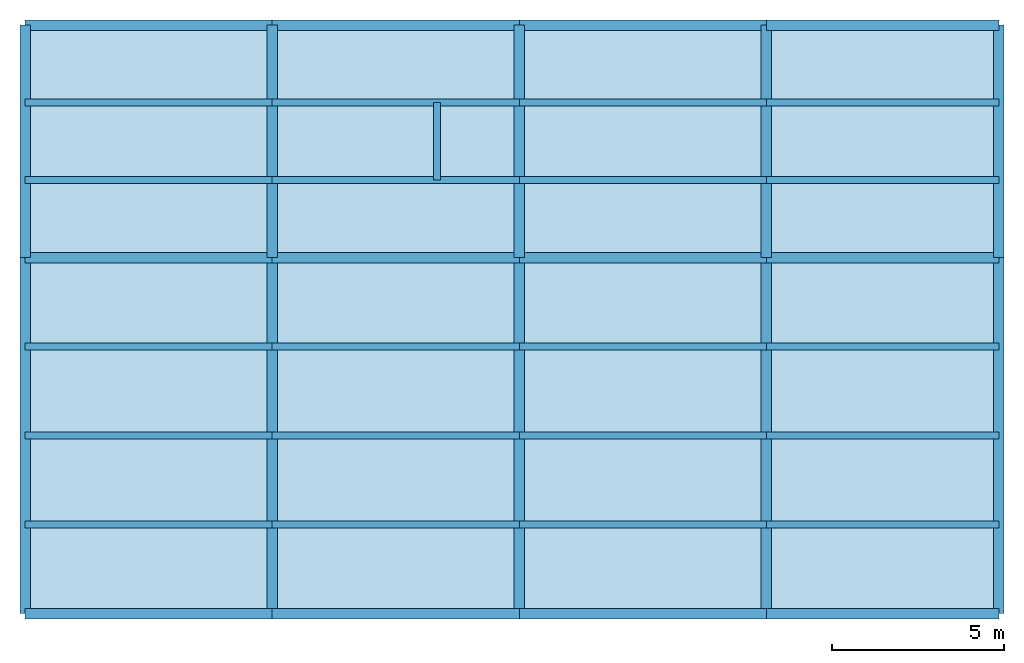
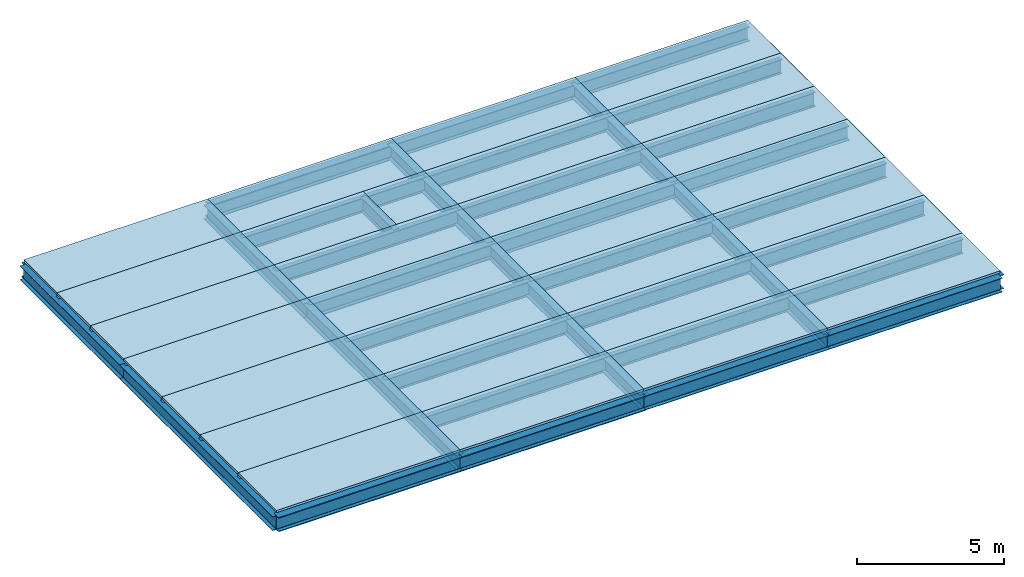
# One storey: 43 beams, 29 slabs.
"""IFC2X3 building model written with IfcOpenShell, lengths in millimetres."""

from ifc_helpers import new_model, si_unit, frame, origin_with_axes, origin_2d_with_axis, place, context, subcontext, project, spatial, polyline, i_section, outline, extrude, material, layer, layer_set, layer_usage, type_object, element, save


model = new_model("IFC2X3")

# Units and contexts
model_context = context("Model", 3, precision=1e-05, world=origin_with_axes())
body_context = subcontext(model_context, "Body", "Model", "MODEL_VIEW")
ifc_project = project(units=[si_unit("LENGTHUNIT", "METRE", prefix="MILLI"), si_unit("AREAUNIT", "SQUARE_METRE"), si_unit("VOLUMEUNIT", "CUBIC_METRE"), si_unit("MASSUNIT", "GRAM", prefix="KILO"), si_unit("TIMEUNIT", "SECOND"), si_unit("PLANEANGLEUNIT", "RADIAN"), si_unit("SOLIDANGLEUNIT", "STERADIAN"), si_unit("THERMODYNAMICTEMPERATUREUNIT", "DEGREE_CELSIUS"), si_unit("LUMINOUSINTENSITYUNIT", "LUMEN")], contexts=[model_context])

# Site, building, storey
site_placement = place(None, origin_with_axes())
site = spatial("IfcSite", under=ifc_project, at=site_placement, CompositionType="ELEMENT")
building_placement = place(site_placement, origin_with_axes())
building = spatial("IfcBuilding", under=site, at=building_placement, Name="Undefined", CompositionType="ELEMENT")
storey_placement = place(building_placement, origin_with_axes())
storey = spatial("IfcBuildingStorey", under=building, at=storey_placement, Name="R", CompositionType="ELEMENT", Elevation=0.0)

# Beams
ifc_material_1 = material(Name="STEEL/SS400")
beam_type_1 = type_object("IfcBeamType", PredefinedType="NOTDEFINED")
for number, where, z_axis, x_axis in (
    (1, (21600.0, 7781.25, 7702.0), (0.0, 0.0, 1.0), (1.0, 0.0, 0.0)),
    (2, (21600.0, 5187.5, 7702.0), (0.0, 0.0, 1.0), (1.0, 0.0, 0.0)),
    (3, (21600.0, 2593.75, 7702.0), (0.0, 0.0, 1.0), (1.0, 0.0, 0.0)),
    (4, (14400.0, 7781.25, 7702.0), (0.0, 0.0, 1.0), (1.0, 0.0, 0.0)),
    (5, (14400.0, 5187.5, 7702.0), (0.0, 0.0, 1.0), (1.0, 0.0, 0.0)),
    (6, (14400.0, 2593.75, 7702.0), (0.0, 0.0, 1.0), (1.0, 0.0, 0.0)),
):
    element("IfcBeam", number, at=place(storey_placement, frame(where, z_axis=z_axis, x_axis=x_axis)), inside=storey, type_object=beam_type_1, material=ifc_material_1, context=body_context, shape_type="SweptSolid", body=[
        extrude(i_section(OverallWidth=199.0, OverallDepth=596.0, WebThickness=10.0, FlangeThickness=15.0, FilletRadius=13.0, at=origin_2d_with_axis()), frame((7200.0, 0.0, 0.0), z_axis=(-1.0, 0.0, 0.0), x_axis=(0.0, -1.0, 0.0)), (0.0, 0.0, 1.0), 7200.0),
    ])
for number, where, z_axis, x_axis in (
    (7, (36000.0, 7781.25, 7702.0), (0.0, 0.0, 1.0), (1.0, 0.0, 0.0)),
    (8, (36000.0, 5187.5, 7702.0), (0.0, 0.0, 1.0), (1.0, 0.0, 0.0)),
    (9, (36000.0, 2593.75, 7702.0), (0.0, 0.0, 1.0), (1.0, 0.0, 0.0)),
):
    element("IfcBeam", number, at=place(storey_placement, frame(where, z_axis=z_axis, x_axis=x_axis)), inside=storey, type_object=beam_type_1, material=ifc_material_1, context=body_context, shape_type="SweptSolid", body=[
        extrude(i_section(OverallWidth=199.0, OverallDepth=596.0, WebThickness=10.0, FlangeThickness=15.0, FilletRadius=13.0, at=origin_2d_with_axis()), frame((6775.0, 0.0, 0.0), z_axis=(-1.0, 0.0, 0.0), x_axis=(0.0, -1.0, 0.0)), (0.0, 0.0, 1.0), 6775.0),
    ])
for number, where, z_axis, x_axis in (
    (10, (28800.0, 7781.25, 7702.0), (0.0, 0.0, 1.0), (1.0, 0.0, 0.0)),
    (11, (28800.0, 5187.5, 7702.0), (0.0, 0.0, 1.0), (1.0, 0.0, 0.0)),
    (12, (28800.0, 2593.75, 7702.0), (0.0, 0.0, 1.0), (1.0, 0.0, 0.0)),
    (13, (14400.0, 14891.7, 7702.0), (0.0, 0.0, 1.0), (1.0, 0.0, 0.0)),
    (14, (14400.0, 12633.3, 7702.0), (0.0, 0.0, 1.0), (1.0, 0.0, 0.0)),
):
    element("IfcBeam", number, at=place(storey_placement, frame(where, z_axis=z_axis, x_axis=x_axis)), inside=storey, type_object=beam_type_1, material=ifc_material_1, context=body_context, shape_type="SweptSolid", body=[
        extrude(i_section(OverallWidth=199.0, OverallDepth=596.0, WebThickness=10.0, FlangeThickness=15.0, FilletRadius=13.0, at=origin_2d_with_axis()), frame((7200.0, 0.0, 0.0), z_axis=(-1.0, 0.0, 0.0), x_axis=(0.0, -1.0, 0.0)), (0.0, 0.0, 1.0), 7200.0),
    ])
for number, where, z_axis, x_axis in (
    (15, (36000.0, 14891.7, 7702.0), (0.0, 0.0, 1.0), (1.0, 0.0, 0.0)),
    (16, (36000.0, 12633.3, 7702.0), (0.0, 0.0, 1.0), (1.0, 0.0, 0.0)),
):
    element("IfcBeam", number, at=place(storey_placement, frame(where, z_axis=z_axis, x_axis=x_axis)), inside=storey, type_object=beam_type_1, material=ifc_material_1, context=body_context, shape_type="SweptSolid", body=[
        extrude(i_section(OverallWidth=199.0, OverallDepth=596.0, WebThickness=10.0, FlangeThickness=15.0, FilletRadius=13.0, at=origin_2d_with_axis()), frame((6775.0, 0.0, 0.0), z_axis=(-1.0, 0.0, 0.0), x_axis=(0.0, -1.0, 0.0)), (0.0, 0.0, 1.0), 6775.0),
    ])
for number, where, z_axis, x_axis in (
    (17, (28800.0, 14891.7, 7702.0), (0.0, 0.0, 1.0), (1.0, 0.0, 0.0)),
    (18, (28800.0, 12633.3, 7702.0), (0.0, 0.0, 1.0), (1.0, 0.0, 0.0)),
):
    element("IfcBeam", number, at=place(storey_placement, frame(where, z_axis=z_axis, x_axis=x_axis)), inside=storey, type_object=beam_type_1, material=ifc_material_1, context=body_context, shape_type="SweptSolid", body=[
        extrude(i_section(OverallWidth=199.0, OverallDepth=596.0, WebThickness=10.0, FlangeThickness=15.0, FilletRadius=13.0, at=origin_2d_with_axis()), frame((7200.0, 0.0, 0.0), z_axis=(-1.0, 0.0, 0.0), x_axis=(0.0, -1.0, 0.0)), (0.0, 0.0, 1.0), 7200.0),
    ])
beam_1_placement = place(storey_placement, frame((26400.0, 12633.3, 7702.0), z_axis=(0.0, 0.0, 1.0), x_axis=(0.0, 1.0, 0.0)))
element("IfcBeam", 19, at=beam_1_placement, inside=storey, type_object=beam_type_1, material=ifc_material_1, context=body_context, shape_type="SweptSolid", body=[
    extrude(i_section(OverallWidth=199.0, OverallDepth=596.0, WebThickness=10.0, FlangeThickness=15.0, FilletRadius=13.0, at=origin_2d_with_axis()), frame((2258.4, 0.0, 0.0), z_axis=(-1.0, 0.0, 0.0), x_axis=(0.0, -1.0, 0.0)), (0.0, 0.0, 1.0), 2258.4),
])
for number, where, z_axis, x_axis in (
    (20, (21600.0, 14891.7, 7702.0), (0.0, 0.0, 1.0), (1.0, 0.0, 0.0)),
    (21, (21600.0, 12633.3, 7702.0), (0.0, 0.0, 1.0), (1.0, 0.0, 0.0)),
):
    element("IfcBeam", number, at=place(storey_placement, frame(where, z_axis=z_axis, x_axis=x_axis)), inside=storey, type_object=beam_type_1, material=ifc_material_1, context=body_context, shape_type="SweptSolid", body=[
        extrude(i_section(OverallWidth=199.0, OverallDepth=596.0, WebThickness=10.0, FlangeThickness=15.0, FilletRadius=13.0, at=origin_2d_with_axis()), frame((7200.0, 0.0, 0.0), z_axis=(-1.0, 0.0, 0.0), x_axis=(0.0, -1.0, 0.0)), (0.0, 0.0, 1.0), 7200.0),
    ])
ifc_material_2 = material(Name="STEEL/SM490")
beam_type_2 = type_object("IfcBeamType", PredefinedType="NOTDEFINED")
beam_2_placement = place(storey_placement, frame((42775.0, 10375.0, 7706.0), z_axis=(0.0, 0.0, 1.0), x_axis=(0.0, 1.0, 0.0)))
element("IfcBeam", 22, at=beam_2_placement, inside=storey, type_object=beam_type_2, material=ifc_material_2, Name="RBB7", context=body_context, shape_type="SweptSolid", body=[
    extrude(i_section(OverallWidth=300.0, OverallDepth=588.0, WebThickness=12.0, FlangeThickness=20.0, FilletRadius=13.0, at=origin_2d_with_axis()), frame((6775.0, 0.0, 0.0), z_axis=(-1.0, 0.0, 0.0), x_axis=(0.0, -1.0, 0.0)), (0.0, 0.0, 1.0), 6775.0),
])
beam_3_placement = place(storey_placement, frame((42775.0, 0.0, 7706.0), z_axis=(0.0, 0.0, 1.0), x_axis=(0.0, 1.0, 0.0)))
element("IfcBeam", 23, at=beam_3_placement, inside=storey, type_object=beam_type_2, material=ifc_material_2, Name="RBA7", context=body_context, shape_type="SweptSolid", body=[
    extrude(i_section(OverallWidth=300.0, OverallDepth=588.0, WebThickness=12.0, FlangeThickness=20.0, FilletRadius=13.0, at=origin_2d_with_axis()), frame((10375.0, 0.0, 0.0), z_axis=(-1.0, 0.0, 0.0), x_axis=(0.0, -1.0, 0.0)), (0.0, 0.0, 1.0), 10375.0),
])
beam_4_placement = place(storey_placement, frame((36000.0, 10375.0, 7706.0), z_axis=(0.0, 0.0, 1.0), x_axis=(0.0, 1.0, 0.0)))
element("IfcBeam", 24, at=beam_4_placement, inside=storey, type_object=beam_type_2, material=ifc_material_2, Name="RBB6", context=body_context, shape_type="SweptSolid", body=[
    extrude(i_section(OverallWidth=300.0, OverallDepth=588.0, WebThickness=12.0, FlangeThickness=20.0, FilletRadius=13.0, at=origin_2d_with_axis()), frame((6775.0, 0.0, 0.0), z_axis=(-1.0, 0.0, 0.0), x_axis=(0.0, -1.0, 0.0)), (0.0, 0.0, 1.0), 6775.0),
])
beam_5_placement = place(storey_placement, frame((36000.0, 0.0, 7706.0), z_axis=(0.0, 0.0, 1.0), x_axis=(0.0, 1.0, 0.0)))
element("IfcBeam", 25, at=beam_5_placement, inside=storey, type_object=beam_type_2, material=ifc_material_2, Name="RBA6", context=body_context, shape_type="SweptSolid", body=[
    extrude(i_section(OverallWidth=300.0, OverallDepth=588.0, WebThickness=12.0, FlangeThickness=20.0, FilletRadius=13.0, at=origin_2d_with_axis()), frame((10375.0, 0.0, 0.0), z_axis=(-1.0, 0.0, 0.0), x_axis=(0.0, -1.0, 0.0)), (0.0, 0.0, 1.0), 10375.0),
])
beam_6_placement = place(storey_placement, frame((28800.0, 10375.0, 7706.0), z_axis=(0.0, 0.0, 1.0), x_axis=(0.0, 1.0, 0.0)))
element("IfcBeam", 26, at=beam_6_placement, inside=storey, type_object=beam_type_2, material=ifc_material_2, Name="RBB5", context=body_context, shape_type="SweptSolid", body=[
    extrude(i_section(OverallWidth=300.0, OverallDepth=588.0, WebThickness=12.0, FlangeThickness=20.0, FilletRadius=13.0, at=origin_2d_with_axis()), frame((6775.0, 0.0, 0.0), z_axis=(-1.0, 0.0, 0.0), x_axis=(0.0, -1.0, 0.0)), (0.0, 0.0, 1.0), 6775.0),
])
beam_7_placement = place(storey_placement, frame((28800.0, 0.0, 7706.0), z_axis=(0.0, 0.0, 1.0), x_axis=(0.0, 1.0, 0.0)))
element("IfcBeam", 27, at=beam_7_placement, inside=storey, type_object=beam_type_2, material=ifc_material_2, Name="RBA5", context=body_context, shape_type="SweptSolid", body=[
    extrude(i_section(OverallWidth=300.0, OverallDepth=588.0, WebThickness=12.0, FlangeThickness=20.0, FilletRadius=13.0, at=origin_2d_with_axis()), frame((10375.0, 0.0, 0.0), z_axis=(-1.0, 0.0, 0.0), x_axis=(0.0, -1.0, 0.0)), (0.0, 0.0, 1.0), 10375.0),
])
beam_8_placement = place(storey_placement, frame((21600.0, 10375.0, 7706.0), z_axis=(0.0, 0.0, 1.0), x_axis=(0.0, 1.0, 0.0)))
element("IfcBeam", 28, at=beam_8_placement, inside=storey, type_object=beam_type_2, material=ifc_material_2, Name="RBB4", context=body_context, shape_type="SweptSolid", body=[
    extrude(i_section(OverallWidth=300.0, OverallDepth=588.0, WebThickness=12.0, FlangeThickness=20.0, FilletRadius=13.0, at=origin_2d_with_axis()), frame((6775.0, 0.0, 0.0), z_axis=(-1.0, 0.0, 0.0), x_axis=(0.0, -1.0, 0.0)), (0.0, 0.0, 1.0), 6775.0),
])
beam_9_placement = place(storey_placement, frame((21600.0, 0.0, 7706.0), z_axis=(0.0, 0.0, 1.0), x_axis=(0.0, 1.0, 0.0)))
element("IfcBeam", 29, at=beam_9_placement, inside=storey, type_object=beam_type_2, material=ifc_material_2, Name="RBA4", context=body_context, shape_type="SweptSolid", body=[
    extrude(i_section(OverallWidth=300.0, OverallDepth=588.0, WebThickness=12.0, FlangeThickness=20.0, FilletRadius=13.0, at=origin_2d_with_axis()), frame((10375.0, 0.0, 0.0), z_axis=(-1.0, 0.0, 0.0), x_axis=(0.0, -1.0, 0.0)), (0.0, 0.0, 1.0), 10375.0),
])
beam_10_placement = place(storey_placement, frame((14400.0, 10375.0, 7706.0), z_axis=(0.0, 0.0, 1.0), x_axis=(0.0, 1.0, 0.0)))
element("IfcBeam", 30, at=beam_10_placement, inside=storey, type_object=beam_type_2, material=ifc_material_2, Name="RBB3", context=body_context, shape_type="SweptSolid", body=[
    extrude(i_section(OverallWidth=300.0, OverallDepth=588.0, WebThickness=12.0, FlangeThickness=20.0, FilletRadius=13.0, at=origin_2d_with_axis()), frame((6775.0, 0.0, 0.0), z_axis=(-1.0, 0.0, 0.0), x_axis=(0.0, -1.0, 0.0)), (0.0, 0.0, 1.0), 6775.0),
])
beam_11_placement = place(storey_placement, frame((14400.0, 0.0, 7706.0), z_axis=(0.0, 0.0, 1.0), x_axis=(0.0, 1.0, 0.0)))
element("IfcBeam", 31, at=beam_11_placement, inside=storey, type_object=beam_type_2, material=ifc_material_2, Name="RBA3", context=body_context, shape_type="SweptSolid", body=[
    extrude(i_section(OverallWidth=300.0, OverallDepth=588.0, WebThickness=12.0, FlangeThickness=20.0, FilletRadius=13.0, at=origin_2d_with_axis()), frame((10375.0, 0.0, 0.0), z_axis=(-1.0, 0.0, 0.0), x_axis=(0.0, -1.0, 0.0)), (0.0, 0.0, 1.0), 10375.0),
])
for number, where, z_axis, x_axis, name in (
    (32, (36000.0, 17150.0, 7706.0), (0.0, 0.0, 1.0), (1.0, 0.0, 0.0), "RGC6"),
    (33, (36000.0, 10375.0, 7706.0), (0.0, 0.0, 1.0), (1.0, 0.0, 0.0), "RGB6"),
    (34, (36000.0, 0.0, 7706.0), (0.0, 0.0, 1.0), (1.0, 0.0, 0.0), "RGA6"),
):
    element("IfcBeam", number, at=place(storey_placement, frame(where, z_axis=z_axis, x_axis=x_axis)), inside=storey, type_object=beam_type_2, material=ifc_material_2, Name=name, context=body_context, shape_type="SweptSolid", body=[
        extrude(i_section(OverallWidth=300.0, OverallDepth=588.0, WebThickness=12.0, FlangeThickness=20.0, FilletRadius=13.0, at=origin_2d_with_axis()), frame((6775.0, 0.0, 0.0), z_axis=(-1.0, 0.0, 0.0), x_axis=(0.0, -1.0, 0.0)), (0.0, 0.0, 1.0), 6775.0),
    ])
for number, where, z_axis, x_axis, name in (
    (35, (28800.0, 17150.0, 7706.0), (0.0, 0.0, 1.0), (1.0, 0.0, 0.0), "RGC5"),
    (36, (28800.0, 10375.0, 7706.0), (0.0, 0.0, 1.0), (1.0, 0.0, 0.0), "RGB5"),
    (37, (28800.0, 0.0, 7706.0), (0.0, 0.0, 1.0), (1.0, 0.0, 0.0), "RGA5"),
):
    element("IfcBeam", number, at=place(storey_placement, frame(where, z_axis=z_axis, x_axis=x_axis)), inside=storey, type_object=beam_type_2, material=ifc_material_2, Name=name, context=body_context, shape_type="SweptSolid", body=[
        extrude(i_section(OverallWidth=300.0, OverallDepth=588.0, WebThickness=12.0, FlangeThickness=20.0, FilletRadius=13.0, at=origin_2d_with_axis()), frame((7200.0, 0.0, 0.0), z_axis=(-1.0, 0.0, 0.0), x_axis=(0.0, -1.0, 0.0)), (0.0, 0.0, 1.0), 7200.0),
    ])
ifc_material_3 = material(Name="STEEL/SN490")
beam_type_3 = type_object("IfcBeamType", PredefinedType="NOTDEFINED")
for number, where, z_axis, x_axis, name in (
    (38, (21600.0, 17150.0, 7700.0), (0.0, 0.0, 1.0), (1.0, 0.0, 0.0), "RGC4"),
    (39, (21600.0, 10375.0, 7700.0), (0.0, 0.0, 1.0), (1.0, 0.0, 0.0), "RGB4"),
    (40, (21600.0, 0.0, 7700.0), (0.0, 0.0, 1.0), (1.0, 0.0, 0.0), "RGA4"),
    (41, (14400.0, 17150.0, 7700.0), (0.0, 0.0, 1.0), (1.0, 0.0, 0.0), "RGC3"),
    (42, (14400.0, 10375.0, 7700.0), (0.0, 0.0, 1.0), (1.0, 0.0, 0.0), "RGB3"),
    (43, (14400.0, 0.0, 7700.0), (0.0, 0.0, 1.0), (1.0, 0.0, 0.0), "RGA3"),
):
    element("IfcBeam", number, at=place(storey_placement, frame(where, z_axis=z_axis, x_axis=x_axis)), inside=storey, type_object=beam_type_3, material=ifc_material_3, Name=name, context=body_context, shape_type="SweptSolid", body=[
        extrude(i_section(OverallWidth=300.0, OverallDepth=600.0, WebThickness=16.0, FlangeThickness=32.0, FilletRadius=13.0, at=origin_2d_with_axis()), frame((7200.0, 0.0, 0.0), z_axis=(-1.0, 0.0, 0.0), x_axis=(0.0, -1.0, 0.0)), (0.0, 0.0, 1.0), 7200.0),
    ])

# Slabs
ifc_material_4 = material(Name="CONCRETE/FC24")
ifc_layer = layer(ifc_material_4, 90.0)
ifc_layer_set = layer_set([ifc_layer], Name="Floor: Insitu CONCRETE/FC24")
ifc_layer_usage_1 = layer_usage(ifc_layer_set, "AXIS3", "POSITIVE", -45.0)
slab_type_1 = type_object("IfcSlabType", PredefinedType="NOTDEFINED")
slab_1_placement = place(storey_placement, frame((26400.0, 12633.3, 8155.0), z_axis=(0.0, 0.0, 1.0), x_axis=(1.0, 0.0, 0.0)))
element("IfcSlab", 44, at=slab_1_placement, inside=storey, type_object=slab_type_1, material=ifc_layer_usage_1, Name="RSB4.4", PredefinedType="FLOOR", context=body_context, shape_type="SweptSolid", body=[
    extrude(outline(polyline([(0.0, 0.0), (2400.0, 0.0), (2400.0, 1341.69995117188), (2400.0, 2258.39990234375), (0.0, 2258.39990234375), (0.0, 0.0)])), frame((0.0, 0.0, -45.0), z_axis=(0.0, 0.0, 1.0), x_axis=(1.0, 0.0, 0.0)), (0.0, 0.0, 1.0), 90.0),
])
ifc_layer_usage_2 = layer_usage(ifc_layer_set, "AXIS3", "POSITIVE", -45.0)
slab_2_placement = place(storey_placement, frame((21600.0, 14891.7, 8155.0), z_axis=(0.0, 0.0, 1.0), x_axis=(1.0, 0.0, 0.0)))
element("IfcSlab", 45, at=slab_2_placement, inside=storey, type_object=slab_type_1, material=ifc_layer_usage_2, Name="RSB4.3", PredefinedType="FLOOR", context=body_context, shape_type="SweptSolid", body=[
    extrude(outline(polyline([(0.0, 0.0), (7200.0, 0.0), (7200.0, 2258.30004882813), (0.0, 2258.30004882813), (0.0, 0.0)])), frame((0.0, 0.0, -45.0), z_axis=(0.0, 0.0, 1.0), x_axis=(1.0, 0.0, 0.0)), (0.0, 0.0, 1.0), 90.0),
])
ifc_layer_usage_3 = layer_usage(ifc_layer_set, "AXIS3", "POSITIVE", -45.0)
slab_3_placement = place(storey_placement, frame((21600.0, 12633.3, 8155.0), z_axis=(0.0, 0.0, 1.0), x_axis=(1.0, 0.0, 0.0)))
element("IfcSlab", 46, at=slab_3_placement, inside=storey, type_object=slab_type_1, material=ifc_layer_usage_3, Name="RSB4.2", PredefinedType="FLOOR", context=body_context, shape_type="SweptSolid", body=[
    extrude(outline(polyline([(0.0, 0.0), (4800.0, 0.0), (4800.0, 2258.39990234375), (0.0, 2258.39990234375), (0.0, 1341.69995117188), (0.0, 0.0)])), frame((0.0, 0.0, -45.0), z_axis=(0.0, 0.0, 1.0), x_axis=(1.0, 0.0, 0.0)), (0.0, 0.0, 1.0), 90.0),
])
ifc_layer_usage_4 = layer_usage(ifc_layer_set, "AXIS3", "POSITIVE", -45.0)
slab_4_placement = place(storey_placement, frame((14400.0, 14891.7, 8155.0), z_axis=(0.0, 0.0, 1.0), x_axis=(1.0, 0.0, 0.0)))
element("IfcSlab", 47, at=slab_4_placement, inside=storey, type_object=slab_type_1, material=ifc_layer_usage_4, Name="RSB3.3", PredefinedType="FLOOR", context=body_context, shape_type="SweptSolid", body=[
    extrude(outline(polyline([(0.0, 0.0), (7200.0, 0.0), (7200.0, 2258.30004882813), (0.0, 2258.30004882813), (0.0, 0.0)])), frame((0.0, 0.0, -45.0), z_axis=(0.0, 0.0, 1.0), x_axis=(1.0, 0.0, 0.0)), (0.0, 0.0, 1.0), 90.0),
])
ifc_layer_usage_5 = layer_usage(ifc_layer_set, "AXIS3", "POSITIVE", -45.0)
slab_5_placement = place(storey_placement, frame((14400.0, 12633.3, 8155.0), z_axis=(0.0, 0.0, 1.0), x_axis=(1.0, 0.0, 0.0)))
element("IfcSlab", 48, at=slab_5_placement, inside=storey, type_object=slab_type_1, material=ifc_layer_usage_5, Name="RSB3.2", PredefinedType="FLOOR", context=body_context, shape_type="SweptSolid", body=[
    extrude(outline(polyline([(0.0, 0.0), (7200.0, 0.0), (7200.0, 1341.69995117188), (7200.0, 2258.39990234375), (0.0, 2258.39990234375), (0.0, 1341.69995117188), (0.0, 0.0)])), frame((0.0, 0.0, -45.0), z_axis=(0.0, 0.0, 1.0), x_axis=(1.0, 0.0, 0.0)), (0.0, 0.0, 1.0), 90.0),
])
ifc_layer_usage_6 = layer_usage(ifc_layer_set, "AXIS3", "POSITIVE", -45.0)
slab_6_placement = place(storey_placement, frame((36000.0, 14891.7, 8155.0), z_axis=(0.0, 0.0, 1.0), x_axis=(1.0, 0.0, 0.0)))
element("IfcSlab", 49, at=slab_6_placement, inside=storey, type_object=slab_type_1, material=ifc_layer_usage_6, Name="RSB6.3", PredefinedType="FLOOR", context=body_context, shape_type="SweptSolid", body=[
    extrude(outline(polyline([(0.0, 0.0), (6775.0, 0.0), (6775.0, 2258.30004882813), (0.0, 2258.30004882813), (0.0, 0.0)])), frame((0.0, 0.0, -45.0), z_axis=(0.0, 0.0, 1.0), x_axis=(1.0, 0.0, 0.0)), (0.0, 0.0, 1.0), 90.0),
])
ifc_layer_usage_7 = layer_usage(ifc_layer_set, "AXIS3", "POSITIVE", -45.0)
slab_7_placement = place(storey_placement, frame((36000.0, 12633.3, 8155.0), z_axis=(0.0, 0.0, 1.0), x_axis=(1.0, 0.0, 0.0)))
element("IfcSlab", 50, at=slab_7_placement, inside=storey, type_object=slab_type_1, material=ifc_layer_usage_7, Name="RSB6.2", PredefinedType="FLOOR", context=body_context, shape_type="SweptSolid", body=[
    extrude(outline(polyline([(0.0, 0.0), (6775.0, 0.0), (6775.0, 1341.69995117188), (6775.0, 2258.39990234375), (0.0, 2258.39990234375), (0.0, 1341.69995117188), (0.0, 0.0)])), frame((0.0, 0.0, -45.0), z_axis=(0.0, 0.0, 1.0), x_axis=(1.0, 0.0, 0.0)), (0.0, 0.0, 1.0), 90.0),
])
ifc_layer_usage_8 = layer_usage(ifc_layer_set, "AXIS3", "POSITIVE", -45.0)
slab_8_placement = place(storey_placement, frame((28800.0, 14891.7, 8155.0), z_axis=(0.0, 0.0, 1.0), x_axis=(1.0, 0.0, 0.0)))
element("IfcSlab", 51, at=slab_8_placement, inside=storey, type_object=slab_type_1, material=ifc_layer_usage_8, Name="RSB5.3", PredefinedType="FLOOR", context=body_context, shape_type="SweptSolid", body=[
    extrude(outline(polyline([(0.0, 0.0), (7200.0, 0.0), (7200.0, 2258.30004882813), (0.0, 2258.30004882813), (0.0, 0.0)])), frame((0.0, 0.0, -45.0), z_axis=(0.0, 0.0, 1.0), x_axis=(1.0, 0.0, 0.0)), (0.0, 0.0, 1.0), 90.0),
])
ifc_layer_usage_9 = layer_usage(ifc_layer_set, "AXIS3", "POSITIVE", -45.0)
slab_9_placement = place(storey_placement, frame((28800.0, 12633.3, 8155.0), z_axis=(0.0, 0.0, 1.0), x_axis=(1.0, 0.0, 0.0)))
element("IfcSlab", 52, at=slab_9_placement, inside=storey, type_object=slab_type_1, material=ifc_layer_usage_9, Name="RSB5.2", PredefinedType="FLOOR", context=body_context, shape_type="SweptSolid", body=[
    extrude(outline(polyline([(0.0, 0.0), (7200.0, 0.0), (7200.0, 1341.69995117188), (7200.0, 2258.39990234375), (0.0, 2258.39990234375), (0.0, 1341.69995117188), (0.0, 0.0)])), frame((0.0, 0.0, -45.0), z_axis=(0.0, 0.0, 1.0), x_axis=(1.0, 0.0, 0.0)), (0.0, 0.0, 1.0), 90.0),
])
ifc_layer_usage_10 = layer_usage(ifc_layer_set, "AXIS3", "POSITIVE", -45.0)
slab_10_placement = place(storey_placement, frame((21600.0, 10375.0, 8155.0), z_axis=(0.0, 0.0, 1.0), x_axis=(1.0, 0.0, 0.0)))
element("IfcSlab", 53, at=slab_10_placement, inside=storey, type_object=slab_type_1, material=ifc_layer_usage_10, Name="RSB4.1", PredefinedType="FLOOR", context=body_context, shape_type="SweptSolid", body=[
    extrude(outline(polyline([(0.0, 0.0), (7200.0, 0.0), (7200.0, 2258.30004882813), (0.0, 2258.30004882813), (0.0, 0.0)])), frame((0.0, 0.0, -45.0), z_axis=(0.0, 0.0, 1.0), x_axis=(1.0, 0.0, 0.0)), (0.0, 0.0, 1.0), 90.0),
])
ifc_layer_usage_11 = layer_usage(ifc_layer_set, "AXIS3", "POSITIVE", -45.0)
slab_11_placement = place(storey_placement, frame((14400.0, 10375.0, 8155.0), z_axis=(0.0, 0.0, 1.0), x_axis=(1.0, 0.0, 0.0)))
element("IfcSlab", 54, at=slab_11_placement, inside=storey, type_object=slab_type_1, material=ifc_layer_usage_11, Name="RSB3.1", PredefinedType="FLOOR", context=body_context, shape_type="SweptSolid", body=[
    extrude(outline(polyline([(0.0, 0.0), (7200.0, 0.0), (7200.0, 2258.30004882813), (0.0, 2258.30004882813), (0.0, 0.0)])), frame((0.0, 0.0, -45.0), z_axis=(0.0, 0.0, 1.0), x_axis=(1.0, 0.0, 0.0)), (0.0, 0.0, 1.0), 90.0),
])
ifc_layer_usage_12 = layer_usage(ifc_layer_set, "AXIS3", "POSITIVE", -45.0)
slab_12_placement = place(storey_placement, frame((36000.0, 10375.0, 8155.0), z_axis=(0.0, 0.0, 1.0), x_axis=(1.0, 0.0, 0.0)))
element("IfcSlab", 55, at=slab_12_placement, inside=storey, type_object=slab_type_1, material=ifc_layer_usage_12, Name="RSB6.1", PredefinedType="FLOOR", context=body_context, shape_type="SweptSolid", body=[
    extrude(outline(polyline([(0.0, 0.0), (6775.0, 0.0), (6775.0, 2258.30004882813), (0.0, 2258.30004882813), (0.0, 0.0)])), frame((0.0, 0.0, -45.0), z_axis=(0.0, 0.0, 1.0), x_axis=(1.0, 0.0, 0.0)), (0.0, 0.0, 1.0), 90.0),
])
ifc_layer_usage_13 = layer_usage(ifc_layer_set, "AXIS3", "POSITIVE", -45.0)
slab_13_placement = place(storey_placement, frame((28800.0, 10375.0, 8155.0), z_axis=(0.0, 0.0, 1.0), x_axis=(1.0, 0.0, 0.0)))
element("IfcSlab", 56, at=slab_13_placement, inside=storey, type_object=slab_type_1, material=ifc_layer_usage_13, Name="RSB5.1", PredefinedType="FLOOR", context=body_context, shape_type="SweptSolid", body=[
    extrude(outline(polyline([(0.0, 0.0), (7200.0, 0.0), (7200.0, 2258.30004882813), (0.0, 2258.30004882813), (0.0, 0.0)])), frame((0.0, 0.0, -45.0), z_axis=(0.0, 0.0, 1.0), x_axis=(1.0, 0.0, 0.0)), (0.0, 0.0, 1.0), 90.0),
])
ifc_layer_usage_14 = layer_usage(ifc_layer_set, "AXIS3", "POSITIVE", -45.0)
slab_type_2 = type_object("IfcSlabType", PredefinedType="NOTDEFINED")
slab_14_placement = place(storey_placement, frame((21600.0, 7781.25, 8155.0), z_axis=(0.0, 0.0, 1.0), x_axis=(1.0, 0.0, 0.0)))
element("IfcSlab", 57, at=slab_14_placement, inside=storey, type_object=slab_type_2, material=ifc_layer_usage_14, Name="RSA4.4", PredefinedType="FLOOR", context=body_context, shape_type="SweptSolid", body=[
    extrude(outline(polyline([(0.0, 0.0), (7200.0, 0.0), (7200.0, 2593.75), (0.0, 2593.75), (0.0, 0.0)])), frame((0.0, 0.0, -45.0), z_axis=(0.0, 0.0, 1.0), x_axis=(1.0, 0.0, 0.0)), (0.0, 0.0, 1.0), 90.0),
])
ifc_layer_usage_15 = layer_usage(ifc_layer_set, "AXIS3", "POSITIVE", -45.0)
slab_15_placement = place(storey_placement, frame((21600.0, 5187.5, 8155.0), z_axis=(0.0, 0.0, 1.0), x_axis=(1.0, 0.0, 0.0)))
element("IfcSlab", 58, at=slab_15_placement, inside=storey, type_object=slab_type_2, material=ifc_layer_usage_15, Name="RSA4.3", PredefinedType="FLOOR", context=body_context, shape_type="SweptSolid", body=[
    extrude(outline(polyline([(0.0, 0.0), (7200.0, 0.0), (7200.0, 1587.5), (7200.0, 2593.75), (0.0, 2593.75), (0.0, 1587.5), (0.0, 0.0)])), frame((0.0, 0.0, -45.0), z_axis=(0.0, 0.0, 1.0), x_axis=(1.0, 0.0, 0.0)), (0.0, 0.0, 1.0), 90.0),
])
ifc_layer_usage_16 = layer_usage(ifc_layer_set, "AXIS3", "POSITIVE", -45.0)
slab_16_placement = place(storey_placement, frame((21600.0, 2593.75, 8155.0), z_axis=(0.0, 0.0, 1.0), x_axis=(1.0, 0.0, 0.0)))
element("IfcSlab", 59, at=slab_16_placement, inside=storey, type_object=slab_type_2, material=ifc_layer_usage_16, Name="RSA4.2", PredefinedType="FLOOR", context=body_context, shape_type="SweptSolid", body=[
    extrude(outline(polyline([(0.0, 0.0), (7200.0, 0.0), (7200.0, 581.25), (7200.0, 2593.75), (0.0, 2593.75), (0.0, 581.25), (0.0, 0.0)])), frame((0.0, 0.0, -45.0), z_axis=(0.0, 0.0, 1.0), x_axis=(1.0, 0.0, 0.0)), (0.0, 0.0, 1.0), 90.0),
])
ifc_layer_usage_17 = layer_usage(ifc_layer_set, "AXIS3", "POSITIVE", -45.0)
slab_17_placement = place(storey_placement, frame((14400.0, 7781.25, 8155.0), z_axis=(0.0, 0.0, 1.0), x_axis=(1.0, 0.0, 0.0)))
element("IfcSlab", 60, at=slab_17_placement, inside=storey, type_object=slab_type_2, material=ifc_layer_usage_17, Name="RSA3.4", PredefinedType="FLOOR", context=body_context, shape_type="SweptSolid", body=[
    extrude(outline(polyline([(0.0, 0.0), (7200.0, 0.0), (7200.0, 2593.75), (0.0, 2593.75), (0.0, 0.0)])), frame((0.0, 0.0, -45.0), z_axis=(0.0, 0.0, 1.0), x_axis=(1.0, 0.0, 0.0)), (0.0, 0.0, 1.0), 90.0),
])
ifc_layer_usage_18 = layer_usage(ifc_layer_set, "AXIS3", "POSITIVE", -45.0)
slab_18_placement = place(storey_placement, frame((14400.0, 5187.5, 8155.0), z_axis=(0.0, 0.0, 1.0), x_axis=(1.0, 0.0, 0.0)))
element("IfcSlab", 61, at=slab_18_placement, inside=storey, type_object=slab_type_2, material=ifc_layer_usage_18, Name="RSA3.3", PredefinedType="FLOOR", context=body_context, shape_type="SweptSolid", body=[
    extrude(outline(polyline([(0.0, 0.0), (7200.0, 0.0), (7200.0, 1587.5), (7200.0, 2593.75), (0.0, 2593.75), (0.0, 1587.5), (0.0, 0.0)])), frame((0.0, 0.0, -45.0), z_axis=(0.0, 0.0, 1.0), x_axis=(1.0, 0.0, 0.0)), (0.0, 0.0, 1.0), 90.0),
])
ifc_layer_usage_19 = layer_usage(ifc_layer_set, "AXIS3", "POSITIVE", -45.0)
slab_19_placement = place(storey_placement, frame((14400.0, 2593.75, 8155.0), z_axis=(0.0, 0.0, 1.0), x_axis=(1.0, 0.0, 0.0)))
element("IfcSlab", 62, at=slab_19_placement, inside=storey, type_object=slab_type_2, material=ifc_layer_usage_19, Name="RSA3.2", PredefinedType="FLOOR", context=body_context, shape_type="SweptSolid", body=[
    extrude(outline(polyline([(0.0, 0.0), (7200.0, 0.0), (7200.0, 581.25), (7200.0, 2593.75), (0.0, 2593.75), (0.0, 581.25), (0.0, 0.0)])), frame((0.0, 0.0, -45.0), z_axis=(0.0, 0.0, 1.0), x_axis=(1.0, 0.0, 0.0)), (0.0, 0.0, 1.0), 90.0),
])
ifc_layer_usage_20 = layer_usage(ifc_layer_set, "AXIS3", "POSITIVE", -45.0)
slab_20_placement = place(storey_placement, frame((36000.0, 7781.25, 8155.0), z_axis=(0.0, 0.0, 1.0), x_axis=(1.0, 0.0, 0.0)))
element("IfcSlab", 63, at=slab_20_placement, inside=storey, type_object=slab_type_2, material=ifc_layer_usage_20, Name="RSA6.4", PredefinedType="FLOOR", context=body_context, shape_type="SweptSolid", body=[
    extrude(outline(polyline([(0.0, 0.0), (6775.0, 0.0), (6775.0, 2593.75), (0.0, 2593.75), (0.0, 0.0)])), frame((0.0, 0.0, -45.0), z_axis=(0.0, 0.0, 1.0), x_axis=(1.0, 0.0, 0.0)), (0.0, 0.0, 1.0), 90.0),
])
ifc_layer_usage_21 = layer_usage(ifc_layer_set, "AXIS3", "POSITIVE", -45.0)
slab_21_placement = place(storey_placement, frame((36000.0, 5187.5, 8155.0), z_axis=(0.0, 0.0, 1.0), x_axis=(1.0, 0.0, 0.0)))
element("IfcSlab", 64, at=slab_21_placement, inside=storey, type_object=slab_type_2, material=ifc_layer_usage_21, Name="RSA6.3", PredefinedType="FLOOR", context=body_context, shape_type="SweptSolid", body=[
    extrude(outline(polyline([(0.0, 0.0), (6775.0, 0.0), (6775.0, 1587.5), (6775.0, 2593.75), (0.0, 2593.75), (0.0, 1587.5), (0.0, 0.0)])), frame((0.0, 0.0, -45.0), z_axis=(0.0, 0.0, 1.0), x_axis=(1.0, 0.0, 0.0)), (0.0, 0.0, 1.0), 90.0),
])
ifc_layer_usage_22 = layer_usage(ifc_layer_set, "AXIS3", "POSITIVE", -45.0)
slab_22_placement = place(storey_placement, frame((36000.0, 2593.75, 8155.0), z_axis=(0.0, 0.0, 1.0), x_axis=(1.0, 0.0, 0.0)))
element("IfcSlab", 65, at=slab_22_placement, inside=storey, type_object=slab_type_2, material=ifc_layer_usage_22, Name="RSA6.2", PredefinedType="FLOOR", context=body_context, shape_type="SweptSolid", body=[
    extrude(outline(polyline([(0.0, 0.0), (6775.0, 0.0), (6775.0, 581.25), (6775.0, 2593.75), (0.0, 2593.75), (0.0, 581.25), (0.0, 0.0)])), frame((0.0, 0.0, -45.0), z_axis=(0.0, 0.0, 1.0), x_axis=(1.0, 0.0, 0.0)), (0.0, 0.0, 1.0), 90.0),
])
ifc_layer_usage_23 = layer_usage(ifc_layer_set, "AXIS3", "POSITIVE", -45.0)
slab_23_placement = place(storey_placement, frame((28800.0, 7781.25, 8155.0), z_axis=(0.0, 0.0, 1.0), x_axis=(1.0, 0.0, 0.0)))
element("IfcSlab", 66, at=slab_23_placement, inside=storey, type_object=slab_type_2, material=ifc_layer_usage_23, Name="RSA5.4", PredefinedType="FLOOR", context=body_context, shape_type="SweptSolid", body=[
    extrude(outline(polyline([(0.0, 0.0), (7200.0, 0.0), (7200.0, 2593.75), (0.0, 2593.75), (0.0, 0.0)])), frame((0.0, 0.0, -45.0), z_axis=(0.0, 0.0, 1.0), x_axis=(1.0, 0.0, 0.0)), (0.0, 0.0, 1.0), 90.0),
])
ifc_layer_usage_24 = layer_usage(ifc_layer_set, "AXIS3", "POSITIVE", -45.0)
slab_24_placement = place(storey_placement, frame((28800.0, 5187.5, 8155.0), z_axis=(0.0, 0.0, 1.0), x_axis=(1.0, 0.0, 0.0)))
element("IfcSlab", 67, at=slab_24_placement, inside=storey, type_object=slab_type_2, material=ifc_layer_usage_24, Name="RSA5.3", PredefinedType="FLOOR", context=body_context, shape_type="SweptSolid", body=[
    extrude(outline(polyline([(0.0, 0.0), (7200.0, 0.0), (7200.0, 1587.5), (7200.0, 2593.75), (0.0, 2593.75), (0.0, 1587.5), (0.0, 0.0)])), frame((0.0, 0.0, -45.0), z_axis=(0.0, 0.0, 1.0), x_axis=(1.0, 0.0, 0.0)), (0.0, 0.0, 1.0), 90.0),
])
ifc_layer_usage_25 = layer_usage(ifc_layer_set, "AXIS3", "POSITIVE", -45.0)
slab_25_placement = place(storey_placement, frame((28800.0, 2593.75, 8155.0), z_axis=(0.0, 0.0, 1.0), x_axis=(1.0, 0.0, 0.0)))
element("IfcSlab", 68, at=slab_25_placement, inside=storey, type_object=slab_type_2, material=ifc_layer_usage_25, Name="RSA5.2", PredefinedType="FLOOR", context=body_context, shape_type="SweptSolid", body=[
    extrude(outline(polyline([(0.0, 0.0), (7200.0, 0.0), (7200.0, 581.25), (7200.0, 2593.75), (0.0, 2593.75), (0.0, 581.25), (0.0, 0.0)])), frame((0.0, 0.0, -45.0), z_axis=(0.0, 0.0, 1.0), x_axis=(1.0, 0.0, 0.0)), (0.0, 0.0, 1.0), 90.0),
])
ifc_layer_usage_26 = layer_usage(ifc_layer_set, "AXIS3", "POSITIVE", -45.0)
slab_26_placement = place(storey_placement, frame((21600.0, 0.0, 8155.0), z_axis=(0.0, 0.0, 1.0), x_axis=(1.0, 0.0, 0.0)))
element("IfcSlab", 69, at=slab_26_placement, inside=storey, type_object=slab_type_2, material=ifc_layer_usage_26, Name="RSA4.1", PredefinedType="FLOOR", context=body_context, shape_type="SweptSolid", body=[
    extrude(outline(polyline([(0.0, 0.0), (7200.0, 0.0), (7200.0, 2593.75), (0.0, 2593.75), (0.0, 0.0)])), frame((0.0, 0.0, -45.0), z_axis=(0.0, 0.0, 1.0), x_axis=(1.0, 0.0, 0.0)), (0.0, 0.0, 1.0), 90.0),
])
ifc_layer_usage_27 = layer_usage(ifc_layer_set, "AXIS3", "POSITIVE", -45.0)
slab_27_placement = place(storey_placement, frame((14400.0, 0.0, 8155.0), z_axis=(0.0, 0.0, 1.0), x_axis=(1.0, 0.0, 0.0)))
element("IfcSlab", 70, at=slab_27_placement, inside=storey, type_object=slab_type_2, material=ifc_layer_usage_27, Name="RSA3.1", PredefinedType="FLOOR", context=body_context, shape_type="SweptSolid", body=[
    extrude(outline(polyline([(0.0, 0.0), (7200.0, 0.0), (7200.0, 2593.75), (0.0, 2593.75), (0.0, 0.0)])), frame((0.0, 0.0, -45.0), z_axis=(0.0, 0.0, 1.0), x_axis=(1.0, 0.0, 0.0)), (0.0, 0.0, 1.0), 90.0),
])
ifc_layer_usage_28 = layer_usage(ifc_layer_set, "AXIS3", "POSITIVE", -45.0)
slab_28_placement = place(storey_placement, frame((36000.0, 0.0, 8155.0), z_axis=(0.0, 0.0, 1.0), x_axis=(1.0, 0.0, 0.0)))
element("IfcSlab", 71, at=slab_28_placement, inside=storey, type_object=slab_type_2, material=ifc_layer_usage_28, Name="RSA6.1", PredefinedType="FLOOR", context=body_context, shape_type="SweptSolid", body=[
    extrude(outline(polyline([(0.0, 0.0), (6775.0, 0.0), (6775.0, 2593.75), (0.0, 2593.75), (0.0, 0.0)])), frame((0.0, 0.0, -45.0), z_axis=(0.0, 0.0, 1.0), x_axis=(1.0, 0.0, 0.0)), (0.0, 0.0, 1.0), 90.0),
])
ifc_layer_usage_29 = layer_usage(ifc_layer_set, "AXIS3", "POSITIVE", -45.0)
slab_29_placement = place(storey_placement, frame((28800.0, 0.0, 8155.0), z_axis=(0.0, 0.0, 1.0), x_axis=(1.0, 0.0, 0.0)))
element("IfcSlab", 72, at=slab_29_placement, inside=storey, type_object=slab_type_2, material=ifc_layer_usage_29, Name="RSA5.1", PredefinedType="FLOOR", context=body_context, shape_type="SweptSolid", body=[
    extrude(outline(polyline([(0.0, 0.0), (7200.0, 0.0), (7200.0, 2593.75), (0.0, 2593.75), (0.0, 0.0)])), frame((0.0, 0.0, -45.0), z_axis=(0.0, 0.0, 1.0), x_axis=(1.0, 0.0, 0.0)), (0.0, 0.0, 1.0), 90.0),
])

save(model, "model.ifc")
